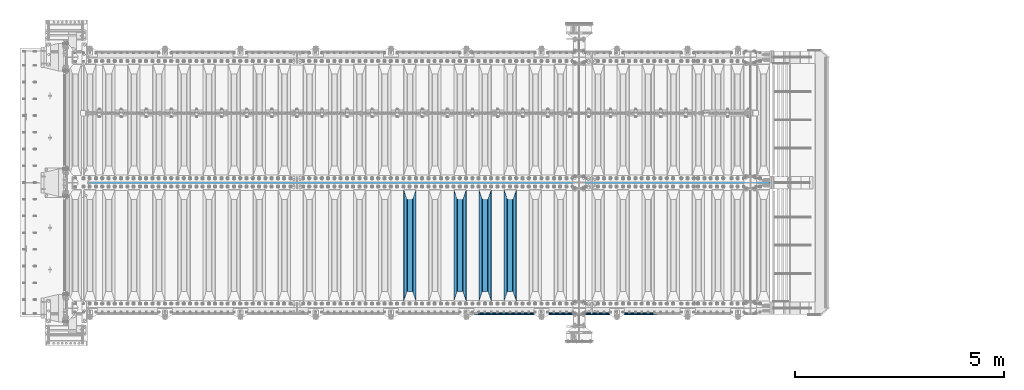
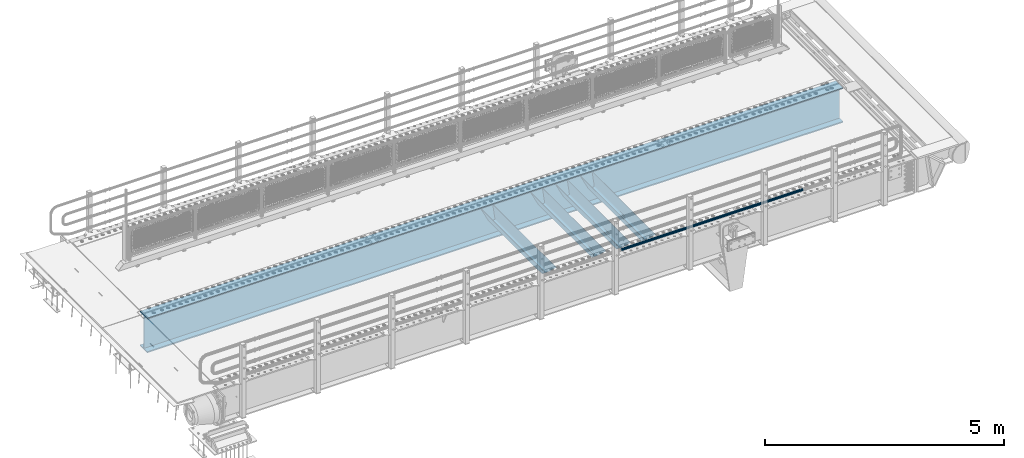
# One storey, part 99 of 208: 6 beams.
"""IFC2X3 building model written with IfcOpenShell, lengths in millimetres."""

from ifc_helpers import new_model, si_unit, frame, origin_with_axes, place, context, subcontext, project, spatial, faceted_brep, material, type_object, element, save


model = new_model("IFC2X3")

# Units and contexts
model_context = context("Model", 3, precision=1e-05, world=origin_with_axes())
body_context = subcontext(model_context, "Body", "Model", "MODEL_VIEW")
ifc_project = project(units=[si_unit("LENGTHUNIT", "METRE", prefix="MILLI"), si_unit("AREAUNIT", "SQUARE_METRE"), si_unit("VOLUMEUNIT", "CUBIC_METRE"), si_unit("MASSUNIT", "GRAM", prefix="KILO"), si_unit("TIMEUNIT", "SECOND"), si_unit("PLANEANGLEUNIT", "RADIAN"), si_unit("SOLIDANGLEUNIT", "STERADIAN"), si_unit("THERMODYNAMICTEMPERATUREUNIT", "DEGREE_CELSIUS"), si_unit("LUMINOUSINTENSITYUNIT", "LUMEN")], contexts=[model_context])

# Site, building, storey
site_placement = place(None, origin_with_axes())
site = spatial("IfcSite", under=ifc_project, at=site_placement, CompositionType="ELEMENT")
building_placement = place(site_placement, origin_with_axes())
building = spatial("IfcBuilding", under=site, at=building_placement, Name="Standard", CompositionType="ELEMENT")
storey_placement = place(building_placement, origin_with_axes())
storey = spatial("IfcBuildingStorey", under=building, at=storey_placement, Name="Undefined", CompositionType="ELEMENT", Elevation=0.0)

# Beams
ifc_material_1 = material(Name="STEEL/S355N")
beam_type_1 = type_object("IfcBeamType", PredefinedType="NOTDEFINED")
beam_1_placement = place(storey_placement, frame((-31850.0, 175.0, -115.0), z_axis=(0.0, 0.0, 1.0), x_axis=(0.0, 1.0, 0.0)))
element("IfcBeam", 1, at=beam_1_placement, inside=storey, type_object=beam_type_1, material=ifc_material_1, context=body_context, shape_type="Brep", body=[
    faceted_brep([(0.0, 150.0, 115.0), (0.0, 143.689999999999, 115.0), (2650.00000000297, 143.689999999999, 115.0), (2650.00000000297, 150.0, 115.0), (2650.00000000297, 142.059565218402, 110.0000000031), (2650.00000000297, 148.369565218403, 110.0000000031), (2441.90079219208, -80.1103600731112, -98.0992078077845), (2437.7588105432, -77.5672621345584, -102.241189456673), (2434.06523489746, -74.4080125315522, -105.934765102404), (2430.91086095089, -70.710272125576, -109.089139048974), (2428.37322971128, -66.5649389910068, -111.626770288588), (2426.51472138055, -62.0739139532889, -113.485278619323), (2425.38102192091, -57.3475956567672, -114.618978078955), (2424.99999999987, -52.5021667386536, -115.0), (2424.99999999987, 52.5021667386536, -115.0), (2425.38102192091, 57.3475956567672, -114.618978078955), (2426.51472138055, 62.0739139532889, -113.485278619323), (2428.37322971128, 66.5649389910068, -111.626770288588), (2430.91086095089, 70.710272125576, -109.089139048974), (2434.06523489746, 74.4080125315522, -105.934765102404), (2437.7588105432, 77.5672621345584, -102.241189456673), (2441.90079219208, 80.1103600731112, -98.0992078077846), (2446.38936140511, 81.9747917625791, -93.6106385947584), (2448.24948500409, 76.2713538057251, -91.7505149957729), (2444.62967112262, 74.76777986261, -95.3703288772456), (2441.28936334126, 72.7168944282894, -98.710636658607), (2438.31067330438, 70.1691124903846, -101.689326695487), (2435.76682334747, 67.1870637758839, -104.233176652398), (2433.72034654133, 63.8440531834895, -106.279653458539), (2432.22154950041, 60.222258798236, -107.778450499454), (2431.30727574265, 56.4107117849089, -108.692724257221), (2430.99999999987, 52.5031078186876, -109.0), (2430.99999999987, -52.5031078186876, -109.0), (2431.30727574265, -56.4107117849089, -108.692724257221), (2432.22154950041, -60.222258798236, -107.778450499454), (2433.72034654133, -63.8440531834895, -106.279653458539), (2435.76682334747, -67.1870637758839, -104.233176652398), (2438.31067330438, -70.1691124903846, -101.689326695487), (2441.28936334126, -72.7168944282894, -98.7106366586071), (2444.62967112262, -74.76777986261, -95.3703288772457), (2448.24948500409, -76.2713538057251, -91.7505149957729), (2650.00000000297, -142.059565218402, 110.0000000031), (2650.00000000297, -148.369565218403, 110.0000000031), (2446.38936140511, -81.9747917625791, -93.6106385947584), (2650.00000000297, -143.689999999999, 115.0), (2650.00000000297, -150.0, 115.0), (0.0, -143.689999999999, 115.0), (0.0, -150.0, 115.0), (0.0, -148.369565218261, 110.000000002663), (203.610638597421, -81.9747917625791, -93.6106385947584), (208.099207810448, -80.1103600731112, -98.0992078077845), (212.241189459336, -77.5672621345584, -102.241189456673), (215.934765105067, -74.4080125315522, -105.934765102404), (219.089139051637, -70.710272125576, -109.089139048974), (221.626770291251, -66.5649389910068, -111.626770288588), (223.485278621986, -62.0739139532889, -113.485278619323), (224.618978081618, -57.3475956567672, -114.618978078955), (225.000000002663, -52.5021667386536, -115.0), (225.000000002663, 52.5021667386536, -115.0), (224.618978081618, 57.3475956567672, -114.618978078955), (223.485278621986, 62.0739139532889, -113.485278619323), (221.626770291251, 66.5649389910068, -111.626770288588), (219.089139051637, 70.710272125576, -109.089139048974), (215.934765105067, 74.4080125315522, -105.934765102404), (212.241189459336, 77.5672621345584, -102.241189456673), (208.099207810448, 80.1103600731112, -98.0992078077846), (203.610638597421, 81.9747917625791, -93.6106385947584), (0.0, 148.369565218261, 110.000000002663), (0.0, 142.05956521826, 110.000000002663), (201.750514998436, 76.2713538057251, -91.7505149957729), (205.370328879908, 74.76777986261, -95.3703288772456), (208.71063666127, 72.7168944282894, -98.710636658607), (211.68932669815, 70.1691124903846, -101.689326695487), (214.233176655061, 67.1870637758839, -104.233176652398), (216.279653461202, 63.8440531834895, -106.279653458539), (217.778450502116, 60.222258798236, -107.778450499454), (218.692724259884, 56.4107117849089, -108.692724257221), (219.000000002663, 52.5031078186876, -109.0), (219.000000002663, -52.5031078186876, -109.0), (218.692724259884, -56.4107117849089, -108.692724257221), (217.778450502116, -60.222258798236, -107.778450499454), (216.279653461202, -63.8440531834895, -106.279653458539), (214.233176655061, -67.1870637758839, -104.233176652398), (211.68932669815, -70.1691124903846, -101.689326695487), (208.71063666127, -72.7168944282894, -98.7106366586071), (205.370328879908, -74.76777986261, -95.3703288772457), (201.750514998436, -76.2713538057251, -91.7505149957729), (0.0, -142.05956521826, 110.000000002663)], [[[0, 1, 2, 3]], [[3, 2, 4, 5]], [[6, 7, 8, 9, 10, 11, 12, 13, 14, 15, 16, 17, 18, 19, 20, 21, 22, 5, 4, 23, 24, 25, 26, 27, 28, 29, 30, 31, 32, 33, 34, 35, 36, 37, 38, 39, 40, 41, 42, 43]], [[44, 45, 42, 41]], [[46, 47, 45, 44]], [[43, 42, 45, 47, 48, 49]], [[6, 43, 49, 50]], [[7, 6, 50, 51]], [[8, 7, 51, 52]], [[9, 8, 52, 53]], [[10, 9, 53, 54]], [[11, 10, 54, 55]], [[12, 11, 55, 56]], [[13, 12, 56, 57]], [[14, 13, 57, 58]], [[15, 14, 58, 59]], [[16, 15, 59, 60]], [[17, 16, 60, 61]], [[18, 17, 61, 62]], [[19, 18, 62, 63]], [[20, 19, 63, 64]], [[21, 20, 64, 65]], [[22, 21, 65, 66]], [[0, 3, 5, 22, 66, 67]], [[1, 0, 67, 68]], [[23, 4, 2, 1, 68, 69]], [[24, 23, 69, 70]], [[25, 24, 70, 71]], [[26, 25, 71, 72]], [[27, 26, 72, 73]], [[28, 27, 73, 74]], [[29, 28, 74, 75]], [[30, 29, 75, 76]], [[31, 30, 76, 77]], [[32, 31, 77, 78]], [[33, 32, 78, 79]], [[34, 33, 79, 80]], [[35, 34, 80, 81]], [[36, 35, 81, 82]], [[37, 36, 82, 83]], [[38, 37, 83, 84]], [[39, 38, 84, 85]], [[40, 39, 85, 86]], [[46, 44, 41, 40, 86, 87]], [[47, 46, 87, 48]], [[86, 85, 84, 83, 82, 81, 80, 79, 78, 77, 76, 75, 74, 73, 72, 71, 70, 69, 68, 67, 66, 65, 64, 63, 62, 61, 60, 59, 58, 57, 56, 55, 54, 53, 52, 51, 50, 49, 48, 87]]]),
])
beam_2_placement = place(storey_placement, frame((-32450.0, 175.0, -115.0), z_axis=(0.0, 0.0, 1.0), x_axis=(0.0, 1.0, 0.0)))
element("IfcBeam", 2, at=beam_2_placement, inside=storey, type_object=beam_type_1, material=ifc_material_1, context=body_context, shape_type="Brep", body=[
    faceted_brep([(0.0, 150.0, 115.0), (0.0, 143.689999999999, 115.0), (2650.00000000297, 143.689999999999, 115.0), (2650.00000000297, 150.0, 115.0), (2650.00000000297, 142.059565218402, 110.0000000031), (2650.00000000297, 148.369565218403, 110.0000000031), (2441.90079219208, -80.1103600731112, -98.0992078077845), (2437.7588105432, -77.5672621345584, -102.241189456673), (2434.06523489746, -74.4080125315522, -105.934765102404), (2430.91086095089, -70.710272125576, -109.089139048974), (2428.37322971128, -66.5649389910068, -111.626770288588), (2426.51472138055, -62.0739139532889, -113.485278619323), (2425.38102192091, -57.3475956567672, -114.618978078955), (2424.99999999987, -52.5021667386536, -115.0), (2424.99999999987, 52.5021667386536, -115.0), (2425.38102192091, 57.3475956567672, -114.618978078955), (2426.51472138055, 62.0739139532889, -113.485278619323), (2428.37322971128, 66.5649389910068, -111.626770288588), (2430.91086095089, 70.710272125576, -109.089139048974), (2434.06523489746, 74.4080125315522, -105.934765102404), (2437.7588105432, 77.5672621345584, -102.241189456673), (2441.90079219208, 80.1103600731112, -98.0992078077846), (2446.38936140511, 81.9747917625791, -93.6106385947584), (2448.24948500409, 76.2713538057251, -91.7505149957729), (2444.62967112262, 74.76777986261, -95.3703288772456), (2441.28936334126, 72.7168944282894, -98.710636658607), (2438.31067330438, 70.1691124903846, -101.689326695487), (2435.76682334747, 67.1870637758839, -104.233176652398), (2433.72034654133, 63.8440531834895, -106.279653458539), (2432.22154950041, 60.222258798236, -107.778450499454), (2431.30727574265, 56.4107117849089, -108.692724257221), (2430.99999999987, 52.5031078186876, -109.0), (2430.99999999987, -52.5031078186876, -109.0), (2431.30727574265, -56.4107117849089, -108.692724257221), (2432.22154950041, -60.222258798236, -107.778450499454), (2433.72034654133, -63.8440531834895, -106.279653458539), (2435.76682334747, -67.1870637758839, -104.233176652398), (2438.31067330438, -70.1691124903846, -101.689326695487), (2441.28936334126, -72.7168944282894, -98.7106366586071), (2444.62967112262, -74.76777986261, -95.3703288772457), (2448.24948500409, -76.2713538057251, -91.7505149957729), (2650.00000000297, -142.059565218402, 110.0000000031), (2650.00000000297, -148.369565218403, 110.0000000031), (2446.38936140511, -81.9747917625791, -93.6106385947584), (2650.00000000297, -143.689999999999, 115.0), (2650.00000000297, -150.0, 115.0), (0.0, -143.689999999999, 115.0), (0.0, -150.0, 115.0), (0.0, -148.369565218261, 110.000000002663), (203.610638597421, -81.9747917625791, -93.6106385947584), (208.099207810448, -80.1103600731112, -98.0992078077845), (212.241189459336, -77.5672621345584, -102.241189456673), (215.934765105067, -74.4080125315522, -105.934765102404), (219.089139051637, -70.710272125576, -109.089139048974), (221.626770291251, -66.5649389910068, -111.626770288588), (223.485278621986, -62.0739139532889, -113.485278619323), (224.618978081618, -57.3475956567672, -114.618978078955), (225.000000002663, -52.5021667386536, -115.0), (225.000000002663, 52.5021667386536, -115.0), (224.618978081618, 57.3475956567672, -114.618978078955), (223.485278621986, 62.0739139532889, -113.485278619323), (221.626770291251, 66.5649389910068, -111.626770288588), (219.089139051637, 70.710272125576, -109.089139048974), (215.934765105067, 74.4080125315522, -105.934765102404), (212.241189459336, 77.5672621345584, -102.241189456673), (208.099207810448, 80.1103600731112, -98.0992078077846), (203.610638597421, 81.9747917625791, -93.6106385947584), (0.0, 148.369565218261, 110.000000002663), (0.0, 142.05956521826, 110.000000002663), (201.750514998436, 76.2713538057251, -91.7505149957729), (205.370328879908, 74.76777986261, -95.3703288772456), (208.71063666127, 72.7168944282894, -98.710636658607), (211.68932669815, 70.1691124903846, -101.689326695487), (214.233176655061, 67.1870637758839, -104.233176652398), (216.279653461202, 63.8440531834895, -106.279653458539), (217.778450502116, 60.222258798236, -107.778450499454), (218.692724259884, 56.4107117849089, -108.692724257221), (219.000000002663, 52.5031078186876, -109.0), (219.000000002663, -52.5031078186876, -109.0), (218.692724259884, -56.4107117849089, -108.692724257221), (217.778450502116, -60.222258798236, -107.778450499454), (216.279653461202, -63.8440531834895, -106.279653458539), (214.233176655061, -67.1870637758839, -104.233176652398), (211.68932669815, -70.1691124903846, -101.689326695487), (208.71063666127, -72.7168944282894, -98.7106366586071), (205.370328879908, -74.76777986261, -95.3703288772457), (201.750514998436, -76.2713538057251, -91.7505149957729), (0.0, -142.05956521826, 110.000000002663)], [[[0, 1, 2, 3]], [[3, 2, 4, 5]], [[6, 7, 8, 9, 10, 11, 12, 13, 14, 15, 16, 17, 18, 19, 20, 21, 22, 5, 4, 23, 24, 25, 26, 27, 28, 29, 30, 31, 32, 33, 34, 35, 36, 37, 38, 39, 40, 41, 42, 43]], [[44, 45, 42, 41]], [[46, 47, 45, 44]], [[43, 42, 45, 47, 48, 49]], [[6, 43, 49, 50]], [[7, 6, 50, 51]], [[8, 7, 51, 52]], [[9, 8, 52, 53]], [[10, 9, 53, 54]], [[11, 10, 54, 55]], [[12, 11, 55, 56]], [[13, 12, 56, 57]], [[14, 13, 57, 58]], [[15, 14, 58, 59]], [[16, 15, 59, 60]], [[17, 16, 60, 61]], [[18, 17, 61, 62]], [[19, 18, 62, 63]], [[20, 19, 63, 64]], [[21, 20, 64, 65]], [[22, 21, 65, 66]], [[0, 3, 5, 22, 66, 67]], [[1, 0, 67, 68]], [[23, 4, 2, 1, 68, 69]], [[24, 23, 69, 70]], [[25, 24, 70, 71]], [[26, 25, 71, 72]], [[27, 26, 72, 73]], [[28, 27, 73, 74]], [[29, 28, 74, 75]], [[30, 29, 75, 76]], [[31, 30, 76, 77]], [[32, 31, 77, 78]], [[33, 32, 78, 79]], [[34, 33, 79, 80]], [[35, 34, 80, 81]], [[36, 35, 81, 82]], [[37, 36, 82, 83]], [[38, 37, 83, 84]], [[39, 38, 84, 85]], [[40, 39, 85, 86]], [[46, 44, 41, 40, 86, 87]], [[47, 46, 87, 48]], [[86, 85, 84, 83, 82, 81, 80, 79, 78, 77, 76, 75, 74, 73, 72, 71, 70, 69, 68, 67, 66, 65, 64, 63, 62, 61, 60, 59, 58, 57, 56, 55, 54, 53, 52, 51, 50, 49, 48, 87]]]),
])
beam_3_placement = place(storey_placement, frame((-33050.0, 175.0, -115.0), z_axis=(0.0, 0.0, 1.0), x_axis=(0.0, 1.0, 0.0)))
element("IfcBeam", 3, at=beam_3_placement, inside=storey, type_object=beam_type_1, material=ifc_material_1, context=body_context, shape_type="Brep", body=[
    faceted_brep([(0.0, 150.0, 115.0), (0.0, 143.689999999999, 115.0), (2650.00000000297, 143.689999999999, 115.0), (2650.00000000297, 150.0, 115.0), (2650.00000000297, 142.059565218402, 110.0000000031), (2650.00000000297, 148.369565218403, 110.0000000031), (2441.90079219208, -80.1103600731112, -98.0992078077845), (2437.7588105432, -77.5672621345584, -102.241189456673), (2434.06523489746, -74.4080125315522, -105.934765102404), (2430.91086095089, -70.710272125576, -109.089139048974), (2428.37322971128, -66.5649389910068, -111.626770288588), (2426.51472138055, -62.0739139532889, -113.485278619323), (2425.38102192091, -57.3475956567672, -114.618978078955), (2424.99999999987, -52.5021667386536, -115.0), (2424.99999999987, 52.5021667386536, -115.0), (2425.38102192091, 57.3475956567672, -114.618978078955), (2426.51472138055, 62.0739139532889, -113.485278619323), (2428.37322971128, 66.5649389910068, -111.626770288588), (2430.91086095089, 70.710272125576, -109.089139048974), (2434.06523489746, 74.4080125315522, -105.934765102404), (2437.7588105432, 77.5672621345584, -102.241189456673), (2441.90079219208, 80.1103600731112, -98.0992078077846), (2446.38936140511, 81.9747917625791, -93.6106385947584), (2448.24948500409, 76.2713538057251, -91.7505149957729), (2444.62967112262, 74.76777986261, -95.3703288772456), (2441.28936334126, 72.7168944282894, -98.710636658607), (2438.31067330438, 70.1691124903846, -101.689326695487), (2435.76682334747, 67.1870637758839, -104.233176652398), (2433.72034654133, 63.8440531834895, -106.279653458539), (2432.22154950041, 60.222258798236, -107.778450499454), (2431.30727574265, 56.4107117849089, -108.692724257221), (2430.99999999987, 52.5031078186876, -109.0), (2430.99999999987, -52.5031078186876, -109.0), (2431.30727574265, -56.4107117849089, -108.692724257221), (2432.22154950041, -60.222258798236, -107.778450499454), (2433.72034654133, -63.8440531834895, -106.279653458539), (2435.76682334747, -67.1870637758839, -104.233176652398), (2438.31067330438, -70.1691124903846, -101.689326695487), (2441.28936334126, -72.7168944282894, -98.7106366586071), (2444.62967112262, -74.76777986261, -95.3703288772457), (2448.24948500409, -76.2713538057251, -91.7505149957729), (2650.00000000297, -142.059565218402, 110.0000000031), (2650.00000000297, -148.369565218403, 110.0000000031), (2446.38936140511, -81.9747917625791, -93.6106385947584), (2650.00000000297, -143.689999999999, 115.0), (2650.00000000297, -150.0, 115.0), (0.0, -143.689999999999, 115.0), (0.0, -150.0, 115.0), (0.0, -148.369565218261, 110.000000002663), (203.610638597421, -81.9747917625791, -93.6106385947584), (208.099207810448, -80.1103600731112, -98.0992078077845), (212.241189459336, -77.5672621345584, -102.241189456673), (215.934765105067, -74.4080125315522, -105.934765102404), (219.089139051637, -70.710272125576, -109.089139048974), (221.626770291251, -66.5649389910068, -111.626770288588), (223.485278621986, -62.0739139532889, -113.485278619323), (224.618978081618, -57.3475956567672, -114.618978078955), (225.000000002663, -52.5021667386536, -115.0), (225.000000002663, 52.5021667386536, -115.0), (224.618978081618, 57.3475956567672, -114.618978078955), (223.485278621986, 62.0739139532889, -113.485278619323), (221.626770291251, 66.5649389910068, -111.626770288588), (219.089139051637, 70.710272125576, -109.089139048974), (215.934765105067, 74.4080125315522, -105.934765102404), (212.241189459336, 77.5672621345584, -102.241189456673), (208.099207810448, 80.1103600731112, -98.0992078077846), (203.610638597421, 81.9747917625791, -93.6106385947584), (0.0, 148.369565218261, 110.000000002663), (0.0, 142.05956521826, 110.000000002663), (201.750514998436, 76.2713538057251, -91.7505149957729), (205.370328879908, 74.76777986261, -95.3703288772456), (208.71063666127, 72.7168944282894, -98.710636658607), (211.68932669815, 70.1691124903846, -101.689326695487), (214.233176655061, 67.1870637758839, -104.233176652398), (216.279653461202, 63.8440531834895, -106.279653458539), (217.778450502116, 60.222258798236, -107.778450499454), (218.692724259884, 56.4107117849089, -108.692724257221), (219.000000002663, 52.5031078186876, -109.0), (219.000000002663, -52.5031078186876, -109.0), (218.692724259884, -56.4107117849089, -108.692724257221), (217.778450502116, -60.222258798236, -107.778450499454), (216.279653461202, -63.8440531834895, -106.279653458539), (214.233176655061, -67.1870637758839, -104.233176652398), (211.68932669815, -70.1691124903846, -101.689326695487), (208.71063666127, -72.7168944282894, -98.7106366586071), (205.370328879908, -74.76777986261, -95.3703288772457), (201.750514998436, -76.2713538057251, -91.7505149957729), (0.0, -142.05956521826, 110.000000002663)], [[[0, 1, 2, 3]], [[3, 2, 4, 5]], [[6, 7, 8, 9, 10, 11, 12, 13, 14, 15, 16, 17, 18, 19, 20, 21, 22, 5, 4, 23, 24, 25, 26, 27, 28, 29, 30, 31, 32, 33, 34, 35, 36, 37, 38, 39, 40, 41, 42, 43]], [[44, 45, 42, 41]], [[46, 47, 45, 44]], [[43, 42, 45, 47, 48, 49]], [[6, 43, 49, 50]], [[7, 6, 50, 51]], [[8, 7, 51, 52]], [[9, 8, 52, 53]], [[10, 9, 53, 54]], [[11, 10, 54, 55]], [[12, 11, 55, 56]], [[13, 12, 56, 57]], [[14, 13, 57, 58]], [[15, 14, 58, 59]], [[16, 15, 59, 60]], [[17, 16, 60, 61]], [[18, 17, 61, 62]], [[19, 18, 62, 63]], [[20, 19, 63, 64]], [[21, 20, 64, 65]], [[22, 21, 65, 66]], [[0, 3, 5, 22, 66, 67]], [[1, 0, 67, 68]], [[23, 4, 2, 1, 68, 69]], [[24, 23, 69, 70]], [[25, 24, 70, 71]], [[26, 25, 71, 72]], [[27, 26, 72, 73]], [[28, 27, 73, 74]], [[29, 28, 74, 75]], [[30, 29, 75, 76]], [[31, 30, 76, 77]], [[32, 31, 77, 78]], [[33, 32, 78, 79]], [[34, 33, 79, 80]], [[35, 34, 80, 81]], [[36, 35, 81, 82]], [[37, 36, 82, 83]], [[38, 37, 83, 84]], [[39, 38, 84, 85]], [[40, 39, 85, 86]], [[46, 44, 41, 40, 86, 87]], [[47, 46, 87, 48]], [[86, 85, 84, 83, 82, 81, 80, 79, 78, 77, 76, 75, 74, 73, 72, 71, 70, 69, 68, 67, 66, 65, 64, 63, 62, 61, 60, 59, 58, 57, 56, 55, 54, 53, 52, 51, 50, 49, 48, 87]]]),
])
beam_4_placement = place(storey_placement, frame((-34250.0, 175.0, -115.0), z_axis=(0.0, 0.0, 1.0), x_axis=(0.0, 1.0, 0.0)))
element("IfcBeam", 4, at=beam_4_placement, inside=storey, type_object=beam_type_1, material=ifc_material_1, context=body_context, shape_type="Brep", body=[
    faceted_brep([(0.0, 150.0, 115.0), (0.0, 143.689999999999, 115.0), (2650.00000000297, 143.689999999999, 115.0), (2650.00000000297, 150.0, 115.0), (2650.00000000297, 142.059565218402, 110.0000000031), (2650.00000000297, 148.369565218403, 110.0000000031), (2441.90079219208, -80.1103600731112, -98.0992078077845), (2437.7588105432, -77.5672621345584, -102.241189456673), (2434.06523489746, -74.4080125315522, -105.934765102404), (2430.91086095089, -70.710272125576, -109.089139048974), (2428.37322971128, -66.5649389910068, -111.626770288588), (2426.51472138055, -62.0739139532889, -113.485278619323), (2425.38102192091, -57.3475956567672, -114.618978078955), (2424.99999999987, -52.5021667386536, -115.0), (2424.99999999987, 52.5021667386536, -115.0), (2425.38102192091, 57.3475956567672, -114.618978078955), (2426.51472138055, 62.0739139532889, -113.485278619323), (2428.37322971128, 66.5649389910068, -111.626770288588), (2430.91086095089, 70.710272125576, -109.089139048974), (2434.06523489746, 74.4080125315522, -105.934765102404), (2437.7588105432, 77.5672621345584, -102.241189456673), (2441.90079219208, 80.1103600731112, -98.0992078077846), (2446.38936140511, 81.9747917625791, -93.6106385947584), (2448.24948500409, 76.2713538057251, -91.7505149957729), (2444.62967112262, 74.76777986261, -95.3703288772456), (2441.28936334126, 72.7168944282894, -98.710636658607), (2438.31067330438, 70.1691124903846, -101.689326695487), (2435.76682334747, 67.1870637758839, -104.233176652398), (2433.72034654133, 63.8440531834895, -106.279653458539), (2432.22154950041, 60.222258798236, -107.778450499454), (2431.30727574265, 56.4107117849089, -108.692724257221), (2430.99999999987, 52.5031078186876, -109.0), (2430.99999999987, -52.5031078186876, -109.0), (2431.30727574265, -56.4107117849089, -108.692724257221), (2432.22154950041, -60.222258798236, -107.778450499454), (2433.72034654133, -63.8440531834895, -106.279653458539), (2435.76682334747, -67.1870637758839, -104.233176652398), (2438.31067330438, -70.1691124903846, -101.689326695487), (2441.28936334126, -72.7168944282894, -98.7106366586071), (2444.62967112262, -74.76777986261, -95.3703288772457), (2448.24948500409, -76.2713538057251, -91.7505149957729), (2650.00000000297, -142.059565218402, 110.0000000031), (2650.00000000297, -148.369565218403, 110.0000000031), (2446.38936140511, -81.9747917625791, -93.6106385947584), (2650.00000000297, -143.689999999999, 115.0), (2650.00000000297, -150.0, 115.0), (0.0, -143.689999999999, 115.0), (0.0, -150.0, 115.0), (0.0, -148.369565218261, 110.000000002663), (203.610638597421, -81.9747917625791, -93.6106385947584), (208.099207810448, -80.1103600731112, -98.0992078077845), (212.241189459336, -77.5672621345584, -102.241189456673), (215.934765105067, -74.4080125315522, -105.934765102404), (219.089139051637, -70.710272125576, -109.089139048974), (221.626770291251, -66.5649389910068, -111.626770288588), (223.485278621986, -62.0739139532889, -113.485278619323), (224.618978081618, -57.3475956567672, -114.618978078955), (225.000000002663, -52.5021667386536, -115.0), (225.000000002663, 52.5021667386536, -115.0), (224.618978081618, 57.3475956567672, -114.618978078955), (223.485278621986, 62.0739139532889, -113.485278619323), (221.626770291251, 66.5649389910068, -111.626770288588), (219.089139051637, 70.710272125576, -109.089139048974), (215.934765105067, 74.4080125315522, -105.934765102404), (212.241189459336, 77.5672621345584, -102.241189456673), (208.099207810448, 80.1103600731112, -98.0992078077846), (203.610638597421, 81.9747917625791, -93.6106385947584), (0.0, 148.369565218261, 110.000000002663), (0.0, 142.05956521826, 110.000000002663), (201.750514998436, 76.2713538057251, -91.7505149957729), (205.370328879908, 74.76777986261, -95.3703288772456), (208.71063666127, 72.7168944282894, -98.710636658607), (211.68932669815, 70.1691124903846, -101.689326695487), (214.233176655061, 67.1870637758839, -104.233176652398), (216.279653461202, 63.8440531834895, -106.279653458539), (217.778450502116, 60.222258798236, -107.778450499454), (218.692724259884, 56.4107117849089, -108.692724257221), (219.000000002663, 52.5031078186876, -109.0), (219.000000002663, -52.5031078186876, -109.0), (218.692724259884, -56.4107117849089, -108.692724257221), (217.778450502116, -60.222258798236, -107.778450499454), (216.279653461202, -63.8440531834895, -106.279653458539), (214.233176655061, -67.1870637758839, -104.233176652398), (211.68932669815, -70.1691124903846, -101.689326695487), (208.71063666127, -72.7168944282894, -98.7106366586071), (205.370328879908, -74.76777986261, -95.3703288772457), (201.750514998436, -76.2713538057251, -91.7505149957729), (0.0, -142.05956521826, 110.000000002663)], [[[0, 1, 2, 3]], [[3, 2, 4, 5]], [[6, 7, 8, 9, 10, 11, 12, 13, 14, 15, 16, 17, 18, 19, 20, 21, 22, 5, 4, 23, 24, 25, 26, 27, 28, 29, 30, 31, 32, 33, 34, 35, 36, 37, 38, 39, 40, 41, 42, 43]], [[44, 45, 42, 41]], [[46, 47, 45, 44]], [[43, 42, 45, 47, 48, 49]], [[6, 43, 49, 50]], [[7, 6, 50, 51]], [[8, 7, 51, 52]], [[9, 8, 52, 53]], [[10, 9, 53, 54]], [[11, 10, 54, 55]], [[12, 11, 55, 56]], [[13, 12, 56, 57]], [[14, 13, 57, 58]], [[15, 14, 58, 59]], [[16, 15, 59, 60]], [[17, 16, 60, 61]], [[18, 17, 61, 62]], [[19, 18, 62, 63]], [[20, 19, 63, 64]], [[21, 20, 64, 65]], [[22, 21, 65, 66]], [[0, 3, 5, 22, 66, 67]], [[1, 0, 67, 68]], [[23, 4, 2, 1, 68, 69]], [[24, 23, 69, 70]], [[25, 24, 70, 71]], [[26, 25, 71, 72]], [[27, 26, 72, 73]], [[28, 27, 73, 74]], [[29, 28, 74, 75]], [[30, 29, 75, 76]], [[31, 30, 76, 77]], [[32, 31, 77, 78]], [[33, 32, 78, 79]], [[34, 33, 79, 80]], [[35, 34, 80, 81]], [[36, 35, 81, 82]], [[37, 36, 82, 83]], [[38, 37, 83, 84]], [[39, 38, 84, 85]], [[40, 39, 85, 86]], [[46, 44, 41, 40, 86, 87]], [[47, 46, 87, 48]], [[86, 85, 84, 83, 82, 81, 80, 79, 78, 77, 76, 75, 74, 73, 72, 71, 70, 69, 68, 67, 66, 65, 64, 63, 62, 61, 60, 59, 58, 57, 56, 55, 54, 53, 52, 51, 50, 49, 48, 87]]]),
])
ifc_material_2 = material()
beam_type_2 = type_object("IfcBeamType", PredefinedType="NOTDEFINED")
beam_5_placement = place(storey_placement, frame((-28328.0000000001, -129.849999999805, 149.849999999725), z_axis=(0.0, 0.0, -1.0), x_axis=(-1.0, 0.0, 0.0)))
element("IfcBeam", 5, at=beam_5_placement, inside=storey, type_object=beam_type_2, material=ifc_material_2, context=body_context, shape_type="Brep", body=[
    faceted_brep([(0.0, -26.5500000000002, 0.0), (0.0, -24.5290015881747, 10.1602451292931), (4384.0, -24.5290015881747, 10.1602451292931), (4384.0, -26.5500000000002, 0.0), (0.0, -18.7736850405026, 18.7736850405028), (4384.0, -18.7736850405026, 18.7736850405028), (0.0, -10.1602451292929, 24.5290015881747), (4384.0, -10.1602451292929, 24.5290015881747), (0.0, 0.0, 26.55), (4384.0, 0.0, 26.55), (0.0, 10.1602451292929, 24.5290015881747), (4384.0, 10.1602451292929, 24.5290015881747), (0.0, 18.7736850405026, 18.7736850405028), (4384.0, 18.7736850405026, 18.7736850405028), (0.0, 24.5290015881747, 10.1602451292931), (4384.0, 24.5290015881747, 10.1602451292931), (0.0, 26.5500000000002, 0.0), (4384.0, 26.5500000000002, 0.0), (0.0, 24.5290015881747, -10.1602451292931), (4384.0, 24.5290015881747, -10.1602451292931), (0.0, 18.7736850405026, -18.7736850405028), (4384.0, 18.7736850405026, -18.7736850405028), (0.0, 10.1602451292929, -24.5290015881747), (4384.0, 10.1602451292929, -24.5290015881747), (0.0, 0.0, -26.55), (4384.0, 0.0, -26.55), (0.0, -10.1602451292929, -24.5290015881747), (4384.0, -10.1602451292929, -24.5290015881747), (0.0, -18.7736850405026, -18.7736850405028), (4384.0, -18.7736850405026, -18.7736850405028), (0.0, -24.5290015881747, -10.1602451292931), (4384.0, -24.5290015881747, -10.1602451292931), (0.0, -30.1499999999996, 0.0), (0.0, -27.8549679052148, -11.5379054858058), (4384.0, -27.8549679052148, -11.5379054858075), (4384.0, -30.1499999999996, 0.0), (0.0, -21.3192694527743, -21.3192694527752), (4384.0, -21.3192694527743, -21.3192694527744), (0.0, -11.5379054858076, -27.8549679052157), (4384.0, -11.5379054858076, -27.8549679052153), (0.0, 0.0, -30.1500000000015), (4384.0, 0.0, -30.15), (0.0, 11.5379054858076, -27.8549679052157), (4384.0, 11.5379054858076, -27.8549679052153), (0.0, 21.3192694527743, -21.3192694527752), (4384.0, 21.3192694527743, -21.3192694527744), (0.0, 27.8549679052157, -11.5379054858058), (4384.0, 27.8549679052157, -11.5379054858074), (0.0, 30.1499999999996, 0.0), (4384.0, 30.1499999999996, 0.0), (0.0, 27.8549679052157, 11.5379054858058), (4384.0, 27.8549679052157, 11.5379054858075), (0.0, 21.3192694527743, 21.3192694527752), (4384.0, 21.3192694527743, 21.3192694527744), (0.0, 11.5379054858076, 27.8549679052157), (4384.0, 11.5379054858076, 27.8549679052153), (0.0, 0.0, 30.1500000000015), (4384.0, 0.0, 30.15), (0.0, -11.5379054858076, 27.8549679052157), (4384.0, -11.5379054858076, 27.8549679052153), (0.0, -21.3192694527743, 21.3192694527752), (4384.0, -21.3192694527743, 21.3192694527744), (0.0, -27.8549679052157, 11.5379054858058), (4384.0, -27.8549679052157, 11.5379054858075)], [[[0, 1, 2, 3]], [[1, 4, 5, 2]], [[4, 6, 7, 5]], [[6, 8, 9, 7]], [[8, 10, 11, 9]], [[10, 12, 13, 11]], [[12, 14, 15, 13]], [[14, 16, 17, 15]], [[16, 18, 19, 17]], [[18, 20, 21, 19]], [[20, 22, 23, 21]], [[22, 24, 25, 23]], [[24, 26, 27, 25]], [[26, 28, 29, 27]], [[28, 30, 31, 29]], [[30, 0, 3, 31]], [[32, 33, 34, 35]], [[33, 36, 37, 34]], [[36, 38, 39, 37]], [[38, 40, 41, 39]], [[40, 42, 43, 41]], [[42, 44, 45, 43]], [[44, 46, 47, 45]], [[46, 48, 49, 47]], [[48, 50, 51, 49]], [[50, 52, 53, 51]], [[52, 54, 55, 53]], [[54, 56, 57, 55]], [[56, 58, 59, 57]], [[58, 60, 61, 59]], [[60, 62, 63, 61]], [[62, 32, 35, 63]], [[37, 39, 41, 43, 45, 47, 49, 51, 53, 55, 57, 59, 61, 63, 35, 34], [5, 7, 9, 11, 13, 15, 17, 19, 21, 23, 25, 27, 29, 31, 3, 2]], [[62, 60, 58, 56, 54, 52, 50, 48, 46, 44, 42, 40, 38, 36, 33, 32], [30, 28, 26, 24, 22, 20, 18, 16, 14, 12, 10, 8, 6, 4, 1, 0]]]),
])
beam_type_3 = type_object("IfcBeamType", Name="HEA900", PredefinedType="NOTDEFINED")
beam_6_placement = place(storey_placement, frame((-42440.0, 3000.0, -445.0), z_axis=(0.0, 0.0, 1.0), x_axis=(1.0, 0.0, 0.0)))
element("IfcBeam", 6, at=beam_6_placement, inside=storey, type_object=beam_type_3, material=ifc_material_1, ObjectType="HEA900", context=body_context, shape_type="Brep", body=[
    faceted_brep([(0.0, 150.0, -445.0), (0.0, 150.0, -415.0), (16807.0, 150.0, -415.0), (16807.0, 150.0, -445.0), (0.0, 8.0, -415.0), (16807.0, 8.0, -415.0), (0.0, 8.0, 415.0), (16807.0, 8.0, 415.0), (0.0, 150.0, 415.0), (16807.0, 150.0, 415.0), (0.0, 150.0, 445.0), (16807.0, 150.0, 445.0), (0.0, -150.0, 445.0), (16807.0, -150.0, 445.0), (0.0, -150.0, 415.0), (16807.0, -150.0, 415.0), (0.0, -8.0, 415.0), (16807.0, -8.0, 415.0), (0.0, -8.0, -415.0), (16807.0, -8.0, -415.0), (0.0, -150.0, -415.0), (16807.0, -150.0, -415.0), (0.0, -150.0, -445.0), (16807.0, -150.0, -445.0)], [[[0, 1, 2, 3]], [[1, 4, 5, 2]], [[4, 6, 7, 5]], [[6, 8, 9, 7]], [[8, 10, 11, 9]], [[10, 12, 13, 11]], [[12, 14, 15, 13]], [[14, 16, 17, 15]], [[16, 18, 19, 17]], [[18, 20, 21, 19]], [[20, 22, 23, 21]], [[22, 0, 3, 23]], [[5, 7, 9, 11, 13, 15, 17, 19, 21, 23, 3, 2]], [[22, 20, 18, 16, 14, 12, 10, 8, 6, 4, 1, 0]]]),
])

save(model, "model.ifc")
